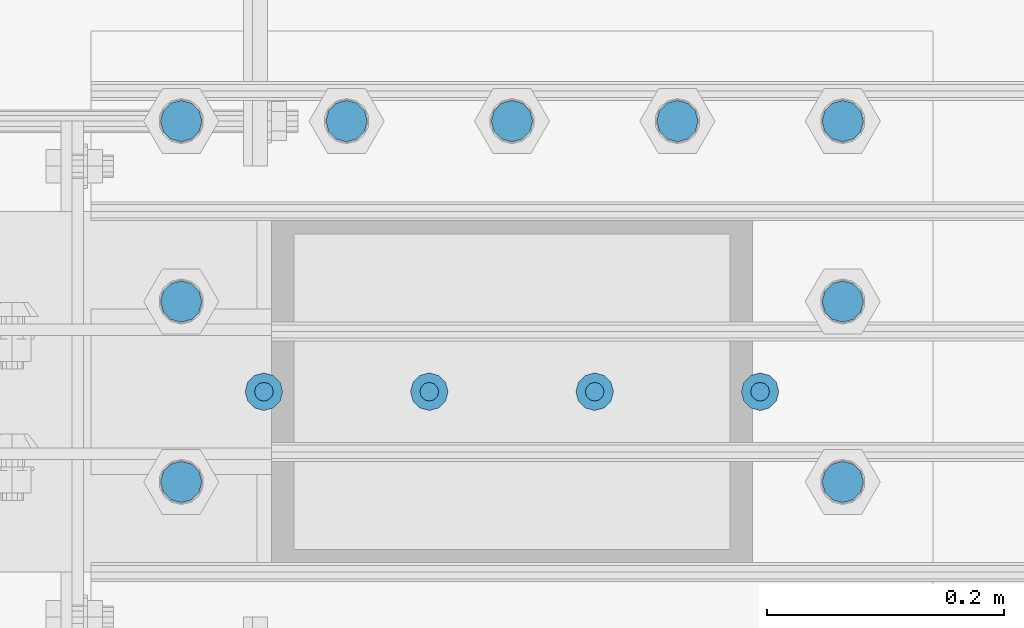
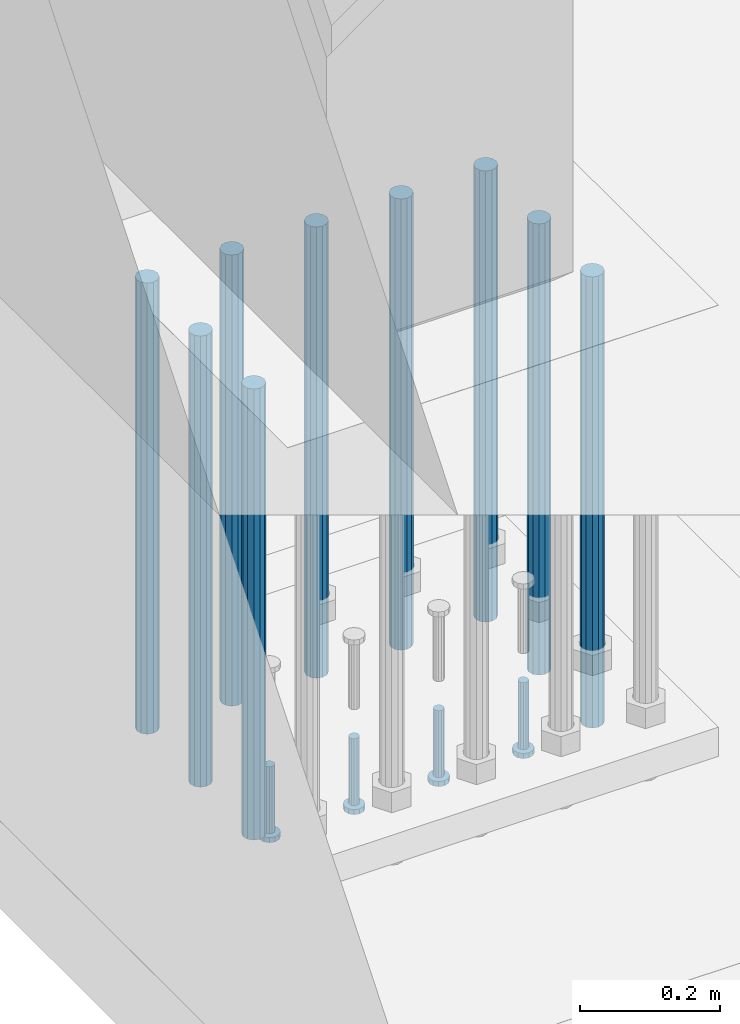
# One storey, part 1090 of 1876: 13 beams, 1 element without a shape of its own.
"""IFC2X3 building model written with IfcOpenShell, lengths in millimetres."""

from ifc_helpers import new_model, si_unit, frame, origin_with_axes, place, context, subcontext, project, spatial, faceted_brep, material, type_object, element, aggregate, save


model = new_model("IFC2X3")

# Units and contexts
model_context = context("Model", 3, precision=1e-05, world=origin_with_axes())
body_context = subcontext(model_context, "Body", "Model", "MODEL_VIEW")
ifc_project = project(units=[si_unit("LENGTHUNIT", "METRE", prefix="MILLI"), si_unit("AREAUNIT", "SQUARE_METRE"), si_unit("VOLUMEUNIT", "CUBIC_METRE"), si_unit("MASSUNIT", "GRAM", prefix="KILO"), si_unit("TIMEUNIT", "SECOND"), si_unit("PLANEANGLEUNIT", "RADIAN"), si_unit("SOLIDANGLEUNIT", "STERADIAN"), si_unit("THERMODYNAMICTEMPERATUREUNIT", "DEGREE_CELSIUS"), si_unit("LUMINOUSINTENSITYUNIT", "LUMEN")], contexts=[model_context])

# Site, building, storey
site_placement = place(None, origin_with_axes())
site = spatial("IfcSite", under=ifc_project, at=site_placement, CompositionType="ELEMENT")
building_placement = place(site_placement, origin_with_axes())
building = spatial("IfcBuilding", under=site, at=building_placement, Name="Undefined", CompositionType="ELEMENT")
storey_placement = place(building_placement, origin_with_axes())
storey = spatial("IfcBuildingStorey", under=building, at=storey_placement, Name="Undefined", CompositionType="ELEMENT", Elevation=0.0)

# Assembly, beams
assembly_placement = place(storey_placement, origin_with_axes())
assembly = element("IfcElementAssembly", 1, at=assembly_placement, inside=storey, Name="PLATE", AssemblyPlace="NOTDEFINED", PredefinedType="RIGID_FRAME")
ifc_material_1 = material(Name="STEEL/A108")
beam_type_1 = type_object("IfcBeamType", Name="5/8-DIA_HEADED ANCHOR STUD", PredefinedType="NOTDEFINED")
beam_1_placement = place(assembly_placement, frame((441.324993896483, -21742.4, -787.400000000001), z_axis=(1.0, 0.0, 0.0), x_axis=(0.0, 0.0, -1.0)))
beam_1 = element("IfcBeam", 2, at=beam_1_placement, type_object=beam_type_1, material=ifc_material_1, Name="HEADED ANCHOR STUD", ObjectType="5/8-DIA_HEADED ANCHOR STUD", context=body_context, shape_type="Brep", body=[
    faceted_brep([(0.0, -7.94000005722046, 0.0), (0.0, -6.86999988555908, -3.97000002861023), (116.84, -6.86999988555908, -3.97000002861023), (116.84, -7.94000005722046, 0.0), (0.0, -3.97000002861023, -6.86999988555908), (116.84, -3.97000002861023, -6.86999988555908), (0.0, 0.0, -7.94000005722046), (116.84, 0.0, -7.94000005722046), (0.0, 3.97000002861023, -6.86999988555908), (116.84, 3.97000002861023, -6.86999988555908), (0.0, 6.86999988555908, -3.97000002861023), (116.84, 6.86999988555908, -3.97000002861023), (0.0, 7.94000005722046, 0.0), (116.84, 7.94000005722046, 0.0), (0.0, 6.86999988555908, 3.97000002861023), (116.84, 6.86999988555908, 3.97000002861023), (0.0, 3.97000002861023, 6.86999988555908), (116.84, 3.97000002861023, 6.86999988555908), (0.0, 0.0, 7.94000005722046), (116.84, 0.0, 7.94000005722046), (0.0, -3.97000002861023, 6.86999988555908), (116.84, -3.97000002861023, 6.86999988555908), (0.0, -6.86999988555908, 3.97000002861023), (116.84, -6.86999988555908, 3.97000002861023), (118.11, -13.75, -7.94000005722046), (118.11, -15.8800001144409, 0.0), (118.11, -7.94000005722046, -13.75), (118.11, 0.0, -15.8800001144409), (118.11, 7.94000005722046, -13.75), (118.11, 13.75, -7.94000005722046), (118.11, 15.8800001144409, 0.0), (118.11, 13.75, 7.94000005722046), (118.11, 7.94000005722046, 13.75), (118.11, 0.0, 15.8800001144409), (118.11, -7.94000005722046, 13.75), (118.11, -13.75, 7.94000005722046), (127.0, -13.75, -7.94000005722046), (127.0, -15.8800001144409, 0.0), (127.0, -7.94000005722046, -13.75), (127.0, 0.0, -15.8800001144409), (127.0, 7.94000005722046, -13.75), (127.0, 13.75, -7.94000005722046), (127.0, 15.8800001144409, 0.0), (127.0, 13.75, 7.94000005722046), (127.0, 7.94000005722046, 13.75), (127.0, 0.0, 15.8800001144409), (127.0, -7.94000005722046, 13.75), (127.0, -13.75, 7.94000005722046)], [[[0, 1, 2, 3]], [[1, 4, 5, 2]], [[4, 6, 7, 5]], [[6, 8, 9, 7]], [[8, 10, 11, 9]], [[10, 12, 13, 11]], [[12, 14, 15, 13]], [[14, 16, 17, 15]], [[16, 18, 19, 17]], [[18, 20, 21, 19]], [[20, 22, 23, 21]], [[22, 0, 3, 23]], [[22, 20, 18, 16, 14, 12, 10, 8, 6, 4, 1, 0]], [[3, 2, 24, 25]], [[2, 5, 26, 24]], [[5, 7, 27, 26]], [[7, 9, 28, 27]], [[9, 11, 29, 28]], [[11, 13, 30, 29]], [[13, 15, 31, 30]], [[15, 17, 32, 31]], [[17, 19, 33, 32]], [[19, 21, 34, 33]], [[21, 23, 35, 34]], [[23, 3, 25, 35]], [[25, 24, 36, 37]], [[24, 26, 38, 36]], [[26, 27, 39, 38]], [[27, 28, 40, 39]], [[28, 29, 41, 40]], [[29, 30, 42, 41]], [[30, 31, 43, 42]], [[31, 32, 44, 43]], [[32, 33, 45, 44]], [[33, 34, 46, 45]], [[34, 35, 47, 46]], [[35, 25, 37, 47]], [[38, 39, 40, 41, 42, 43, 44, 45, 46, 47, 37, 36]]]),
])
beam_2_placement = place(assembly_placement, frame((301.624987792968, -21742.4, -787.400000000001), z_axis=(1.0, 0.0, 0.0), x_axis=(0.0, 0.0, -1.0)))
beam_2 = element("IfcBeam", 3, at=beam_2_placement, type_object=beam_type_1, material=ifc_material_1, Name="HEADED ANCHOR STUD", ObjectType="5/8-DIA_HEADED ANCHOR STUD", context=body_context, shape_type="Brep", body=[
    faceted_brep([(0.0, -7.94000005722046, 0.0), (0.0, -6.86999988555908, -3.97000002861023), (116.84, -6.86999988555908, -3.97000002861023), (116.84, -7.94000005722046, 0.0), (0.0, -3.97000002861023, -6.86999988555908), (116.84, -3.97000002861023, -6.86999988555908), (0.0, 0.0, -7.94000005722046), (116.84, 0.0, -7.94000005722046), (0.0, 3.97000002861023, -6.86999988555908), (116.84, 3.97000002861023, -6.86999988555908), (0.0, 6.86999988555908, -3.97000002861023), (116.84, 6.86999988555908, -3.97000002861023), (0.0, 7.94000005722046, 0.0), (116.84, 7.94000005722046, 0.0), (0.0, 6.86999988555908, 3.97000002861023), (116.84, 6.86999988555908, 3.97000002861023), (0.0, 3.97000002861023, 6.86999988555908), (116.84, 3.97000002861023, 6.86999988555908), (0.0, 0.0, 7.94000005722046), (116.84, 0.0, 7.94000005722046), (0.0, -3.97000002861023, 6.86999988555908), (116.84, -3.97000002861023, 6.86999988555908), (0.0, -6.86999988555908, 3.97000002861023), (116.84, -6.86999988555908, 3.97000002861023), (118.11, -13.75, -7.94000005722046), (118.11, -15.8800001144409, 0.0), (118.11, -7.94000005722046, -13.75), (118.11, 0.0, -15.8800001144409), (118.11, 7.94000005722046, -13.75), (118.11, 13.75, -7.94000005722046), (118.11, 15.8800001144409, 0.0), (118.11, 13.75, 7.94000005722046), (118.11, 7.94000005722046, 13.75), (118.11, 0.0, 15.8800001144409), (118.11, -7.94000005722046, 13.75), (118.11, -13.75, 7.94000005722046), (127.0, -13.75, -7.94000005722046), (127.0, -15.8800001144409, 0.0), (127.0, -7.94000005722046, -13.75), (127.0, 0.0, -15.8800001144409), (127.0, 7.94000005722046, -13.75), (127.0, 13.75, -7.94000005722046), (127.0, 15.8800001144409, 0.0), (127.0, 13.75, 7.94000005722046), (127.0, 7.94000005722046, 13.75), (127.0, 0.0, 15.8800001144409), (127.0, -7.94000005722046, 13.75), (127.0, -13.75, 7.94000005722046)], [[[0, 1, 2, 3]], [[1, 4, 5, 2]], [[4, 6, 7, 5]], [[6, 8, 9, 7]], [[8, 10, 11, 9]], [[10, 12, 13, 11]], [[12, 14, 15, 13]], [[14, 16, 17, 15]], [[16, 18, 19, 17]], [[18, 20, 21, 19]], [[20, 22, 23, 21]], [[22, 0, 3, 23]], [[22, 20, 18, 16, 14, 12, 10, 8, 6, 4, 1, 0]], [[3, 2, 24, 25]], [[2, 5, 26, 24]], [[5, 7, 27, 26]], [[7, 9, 28, 27]], [[9, 11, 29, 28]], [[11, 13, 30, 29]], [[13, 15, 31, 30]], [[15, 17, 32, 31]], [[17, 19, 33, 32]], [[19, 21, 34, 33]], [[21, 23, 35, 34]], [[23, 3, 25, 35]], [[25, 24, 36, 37]], [[24, 26, 38, 36]], [[26, 27, 39, 38]], [[27, 28, 40, 39]], [[28, 29, 41, 40]], [[29, 30, 42, 41]], [[30, 31, 43, 42]], [[31, 32, 44, 43]], [[32, 33, 45, 44]], [[33, 34, 46, 45]], [[34, 35, 47, 46]], [[35, 25, 37, 47]], [[38, 39, 40, 41, 42, 43, 44, 45, 46, 47, 37, 36]]]),
])
beam_3_placement = place(assembly_placement, frame((161.924987792968, -21742.4, -787.400000000001), z_axis=(1.0, 0.0, 0.0), x_axis=(0.0, 0.0, -1.0)))
beam_3 = element("IfcBeam", 4, at=beam_3_placement, type_object=beam_type_1, material=ifc_material_1, Name="HEADED ANCHOR STUD", ObjectType="5/8-DIA_HEADED ANCHOR STUD", context=body_context, shape_type="Brep", body=[
    faceted_brep([(0.0, -7.94000005722046, 0.0), (0.0, -6.86999988555908, -3.97000002861023), (116.84, -6.86999988555908, -3.97000002861023), (116.84, -7.94000005722046, 0.0), (0.0, -3.97000002861023, -6.86999988555908), (116.84, -3.97000002861023, -6.86999988555908), (0.0, 0.0, -7.94000005722046), (116.84, 0.0, -7.94000005722046), (0.0, 3.97000002861023, -6.86999988555908), (116.84, 3.97000002861023, -6.86999988555908), (0.0, 6.86999988555908, -3.97000002861023), (116.84, 6.86999988555908, -3.97000002861023), (0.0, 7.94000005722046, 0.0), (116.84, 7.94000005722046, 0.0), (0.0, 6.86999988555908, 3.97000002861023), (116.84, 6.86999988555908, 3.97000002861023), (0.0, 3.97000002861023, 6.86999988555908), (116.84, 3.97000002861023, 6.86999988555908), (0.0, 0.0, 7.94000005722046), (116.84, 0.0, 7.94000005722046), (0.0, -3.97000002861023, 6.86999988555908), (116.84, -3.97000002861023, 6.86999988555908), (0.0, -6.86999988555908, 3.97000002861023), (116.84, -6.86999988555908, 3.97000002861023), (118.11, -13.75, -7.94000005722046), (118.11, -15.8800001144409, 0.0), (118.11, -7.94000005722046, -13.75), (118.11, 0.0, -15.8800001144409), (118.11, 7.94000005722046, -13.75), (118.11, 13.75, -7.94000005722046), (118.11, 15.8800001144409, 0.0), (118.11, 13.75, 7.94000005722046), (118.11, 7.94000005722046, 13.75), (118.11, 0.0, 15.8800001144409), (118.11, -7.94000005722046, 13.75), (118.11, -13.75, 7.94000005722046), (127.0, -13.75, -7.94000005722046), (127.0, -15.8800001144409, 0.0), (127.0, -7.94000005722046, -13.75), (127.0, 0.0, -15.8800001144409), (127.0, 7.94000005722046, -13.75), (127.0, 13.75, -7.94000005722046), (127.0, 15.8800001144409, 0.0), (127.0, 13.75, 7.94000005722046), (127.0, 7.94000005722046, 13.75), (127.0, 0.0, 15.8800001144409), (127.0, -7.94000005722046, 13.75), (127.0, -13.75, 7.94000005722046)], [[[0, 1, 2, 3]], [[1, 4, 5, 2]], [[4, 6, 7, 5]], [[6, 8, 9, 7]], [[8, 10, 11, 9]], [[10, 12, 13, 11]], [[12, 14, 15, 13]], [[14, 16, 17, 15]], [[16, 18, 19, 17]], [[18, 20, 21, 19]], [[20, 22, 23, 21]], [[22, 0, 3, 23]], [[22, 20, 18, 16, 14, 12, 10, 8, 6, 4, 1, 0]], [[3, 2, 24, 25]], [[2, 5, 26, 24]], [[5, 7, 27, 26]], [[7, 9, 28, 27]], [[9, 11, 29, 28]], [[11, 13, 30, 29]], [[13, 15, 31, 30]], [[15, 17, 32, 31]], [[17, 19, 33, 32]], [[19, 21, 34, 33]], [[21, 23, 35, 34]], [[23, 3, 25, 35]], [[25, 24, 36, 37]], [[24, 26, 38, 36]], [[26, 27, 39, 38]], [[27, 28, 40, 39]], [[28, 29, 41, 40]], [[29, 30, 42, 41]], [[30, 31, 43, 42]], [[31, 32, 44, 43]], [[32, 33, 45, 44]], [[33, 34, 46, 45]], [[34, 35, 47, 46]], [[35, 25, 37, 47]], [[38, 39, 40, 41, 42, 43, 44, 45, 46, 47, 37, 36]]]),
])
beam_4_placement = place(assembly_placement, frame((22.2249877929677, -21742.4, -787.400000000001), z_axis=(1.0, 0.0, 0.0), x_axis=(0.0, 0.0, -1.0)))
beam_4 = element("IfcBeam", 5, at=beam_4_placement, type_object=beam_type_1, material=ifc_material_1, Name="HEADED ANCHOR STUD", ObjectType="5/8-DIA_HEADED ANCHOR STUD", context=body_context, shape_type="Brep", body=[
    faceted_brep([(0.0, -7.94000005722046, 0.0), (0.0, -6.86999988555908, -3.97000002861023), (116.84, -6.86999988555908, -3.97000002861023), (116.84, -7.94000005722046, 0.0), (0.0, -3.97000002861023, -6.86999988555908), (116.84, -3.97000002861023, -6.86999988555908), (0.0, 0.0, -7.94000005722046), (116.84, 0.0, -7.94000005722046), (0.0, 3.97000002861023, -6.86999988555908), (116.84, 3.97000002861023, -6.86999988555908), (0.0, 6.86999988555908, -3.97000002861023), (116.84, 6.86999988555908, -3.97000002861023), (0.0, 7.94000005722046, 0.0), (116.84, 7.94000005722046, 0.0), (0.0, 6.86999988555908, 3.97000002861023), (116.84, 6.86999988555908, 3.97000002861023), (0.0, 3.97000002861023, 6.86999988555908), (116.84, 3.97000002861023, 6.86999988555908), (0.0, 0.0, 7.94000005722046), (116.84, 0.0, 7.94000005722046), (0.0, -3.97000002861023, 6.86999988555908), (116.84, -3.97000002861023, 6.86999988555908), (0.0, -6.86999988555908, 3.97000002861023), (116.84, -6.86999988555908, 3.97000002861023), (118.11, -13.75, -7.94000005722046), (118.11, -15.8800001144409, 0.0), (118.11, -7.94000005722046, -13.75), (118.11, 0.0, -15.8800001144409), (118.11, 7.94000005722046, -13.75), (118.11, 13.75, -7.94000005722046), (118.11, 15.8800001144409, 0.0), (118.11, 13.75, 7.94000005722046), (118.11, 7.94000005722046, 13.75), (118.11, 0.0, 15.8800001144409), (118.11, -7.94000005722046, 13.75), (118.11, -13.75, 7.94000005722046), (127.0, -13.75, -7.94000005722046), (127.0, -15.8800001144409, 0.0), (127.0, -7.94000005722046, -13.75), (127.0, 0.0, -15.8800001144409), (127.0, 7.94000005722046, -13.75), (127.0, 13.75, -7.94000005722046), (127.0, 15.8800001144409, 0.0), (127.0, 13.75, 7.94000005722046), (127.0, 7.94000005722046, 13.75), (127.0, 0.0, 15.8800001144409), (127.0, -7.94000005722046, 13.75), (127.0, -13.75, 7.94000005722046)], [[[0, 1, 2, 3]], [[1, 4, 5, 2]], [[4, 6, 7, 5]], [[6, 8, 9, 7]], [[8, 10, 11, 9]], [[10, 12, 13, 11]], [[12, 14, 15, 13]], [[14, 16, 17, 15]], [[16, 18, 19, 17]], [[18, 20, 21, 19]], [[20, 22, 23, 21]], [[22, 0, 3, 23]], [[22, 20, 18, 16, 14, 12, 10, 8, 6, 4, 1, 0]], [[3, 2, 24, 25]], [[2, 5, 26, 24]], [[5, 7, 27, 26]], [[7, 9, 28, 27]], [[9, 11, 29, 28]], [[11, 13, 30, 29]], [[13, 15, 31, 30]], [[15, 17, 32, 31]], [[17, 19, 33, 32]], [[19, 21, 34, 33]], [[21, 23, 35, 34]], [[23, 3, 25, 35]], [[25, 24, 36, 37]], [[24, 26, 38, 36]], [[26, 27, 39, 38]], [[27, 28, 40, 39]], [[28, 29, 41, 40]], [[29, 30, 42, 41]], [[30, 31, 43, 42]], [[31, 32, 44, 43]], [[32, 33, 45, 44]], [[33, 34, 46, 45]], [[34, 35, 47, 46]], [[35, 25, 37, 47]], [[38, 39, 40, 41, 42, 43, 44, 45, 46, 47, 37, 36]]]),
])
ifc_material_2 = material(Name="STEEL/F1554-55, S1")
beam_type_2 = type_object("IfcBeamType", PredefinedType="NOTDEFINED")
beam_5_placement = place(assembly_placement, frame((371.474987792968, -21513.8, -50.7999999999993), z_axis=(0.0, -1.0, 0.0), x_axis=(0.0, 0.0, -1.0)))
beam_5 = element("IfcBeam", 6, at=beam_5_placement, type_object=beam_type_2, material=ifc_material_2, Name="WELDED HEADED STUD", context=body_context, shape_type="Brep", body=[
    faceted_brep([(0.0, -17.4625, 0.0), (0.0, -15.1229686135857, -8.73125000000073), (787.399999999999, -15.1229686135857, -8.73125000000073), (787.399999999999, -17.4625, 0.0), (0.0, -8.73124999999999, -15.1229686135848), (787.399999999999, -8.73124999999999, -15.1229686135848), (0.0, 0.0, -17.4625000000015), (787.399999999999, 0.0, -17.4625000000015), (0.0, 8.73124999999999, -15.1229686135848), (787.399999999999, 8.73124999999999, -15.1229686135848), (0.0, 15.1229686135858, -8.73125000000073), (787.399999999999, 15.1229686135858, -8.73125000000073), (0.0, 17.4625, 0.0), (787.399999999999, 17.4625, 0.0), (0.0, 15.1229686135858, 8.73125000000073), (787.399999999999, 15.1229686135858, 8.73125000000073), (0.0, 8.73124999999999, 15.1229686135848), (787.399999999999, 8.73124999999999, 15.1229686135848), (0.0, 0.0, 17.4625000000015), (787.399999999999, 0.0, 17.4625000000015), (0.0, -8.73124999999999, 15.1229686135848), (787.399999999999, -8.73124999999999, 15.1229686135848), (0.0, -15.1229686135858, 8.73125000000073), (787.399999999999, -15.1229686135858, 8.73125000000073)], [[[0, 1, 2, 3]], [[1, 4, 5, 2]], [[4, 6, 7, 5]], [[6, 8, 9, 7]], [[8, 10, 11, 9]], [[10, 12, 13, 11]], [[12, 14, 15, 13]], [[14, 16, 17, 15]], [[16, 18, 19, 17]], [[18, 20, 21, 19]], [[20, 22, 23, 21]], [[22, 0, 3, 23]], [[5, 7, 9, 11, 13, 15, 17, 19, 21, 23, 3, 2]], [[22, 20, 18, 16, 14, 12, 10, 8, 6, 4, 1, 0]]]),
])
beam_6_placement = place(assembly_placement, frame((231.774987792968, -21513.8, -50.7999999999993), z_axis=(0.0, -1.0, 0.0), x_axis=(0.0, 0.0, -1.0)))
beam_6 = element("IfcBeam", 7, at=beam_6_placement, type_object=beam_type_2, material=ifc_material_2, Name="WELDED HEADED STUD", context=body_context, shape_type="Brep", body=[
    faceted_brep([(0.0, -17.4625, 0.0), (0.0, -15.1229686135857, -8.73125000000073), (787.399999999999, -15.1229686135857, -8.73125000000073), (787.399999999999, -17.4625, 0.0), (0.0, -8.73124999999999, -15.1229686135848), (787.399999999999, -8.73124999999999, -15.1229686135848), (0.0, 0.0, -17.4625000000015), (787.399999999999, 0.0, -17.4625000000015), (0.0, 8.73124999999999, -15.1229686135848), (787.399999999999, 8.73124999999999, -15.1229686135848), (0.0, 15.1229686135858, -8.73125000000073), (787.399999999999, 15.1229686135858, -8.73125000000073), (0.0, 17.4625, 0.0), (787.399999999999, 17.4625, 0.0), (0.0, 15.1229686135858, 8.73125000000073), (787.399999999999, 15.1229686135858, 8.73125000000073), (0.0, 8.73124999999999, 15.1229686135848), (787.399999999999, 8.73124999999999, 15.1229686135848), (0.0, 0.0, 17.4625000000015), (787.399999999999, 0.0, 17.4625000000015), (0.0, -8.73124999999999, 15.1229686135848), (787.399999999999, -8.73124999999999, 15.1229686135848), (0.0, -15.1229686135858, 8.73125000000073), (787.399999999999, -15.1229686135858, 8.73125000000073)], [[[0, 1, 2, 3]], [[1, 4, 5, 2]], [[4, 6, 7, 5]], [[6, 8, 9, 7]], [[8, 10, 11, 9]], [[10, 12, 13, 11]], [[12, 14, 15, 13]], [[14, 16, 17, 15]], [[16, 18, 19, 17]], [[18, 20, 21, 19]], [[20, 22, 23, 21]], [[22, 0, 3, 23]], [[5, 7, 9, 11, 13, 15, 17, 19, 21, 23, 3, 2]], [[22, 20, 18, 16, 14, 12, 10, 8, 6, 4, 1, 0]]]),
])
beam_7_placement = place(assembly_placement, frame((92.0749877929677, -21513.8, -50.7999999999993), z_axis=(0.0, -1.0, 0.0), x_axis=(0.0, 0.0, -1.0)))
beam_7 = element("IfcBeam", 8, at=beam_7_placement, type_object=beam_type_2, material=ifc_material_2, Name="WELDED HEADED STUD", context=body_context, shape_type="Brep", body=[
    faceted_brep([(0.0, -17.4625, 0.0), (0.0, -15.1229686135857, -8.73125000000073), (787.399999999999, -15.1229686135857, -8.73125000000073), (787.399999999999, -17.4625, 0.0), (0.0, -8.73124999999999, -15.1229686135848), (787.399999999999, -8.73124999999999, -15.1229686135848), (0.0, 0.0, -17.4625000000015), (787.399999999999, 0.0, -17.4625000000015), (0.0, 8.73124999999999, -15.1229686135848), (787.399999999999, 8.73124999999999, -15.1229686135848), (0.0, 15.1229686135858, -8.73125000000073), (787.399999999999, 15.1229686135858, -8.73125000000073), (0.0, 17.4625, 0.0), (787.399999999999, 17.4625, 0.0), (0.0, 15.1229686135858, 8.73125000000073), (787.399999999999, 15.1229686135858, 8.73125000000073), (0.0, 8.73124999999999, 15.1229686135848), (787.399999999999, 8.73124999999999, 15.1229686135848), (0.0, 0.0, 17.4625000000015), (787.399999999999, 0.0, 17.4625000000015), (0.0, -8.73124999999999, 15.1229686135848), (787.399999999999, -8.73124999999999, 15.1229686135848), (0.0, -15.1229686135858, 8.73125000000073), (787.399999999999, -15.1229686135858, 8.73125000000073)], [[[0, 1, 2, 3]], [[1, 4, 5, 2]], [[4, 6, 7, 5]], [[6, 8, 9, 7]], [[8, 10, 11, 9]], [[10, 12, 13, 11]], [[12, 14, 15, 13]], [[14, 16, 17, 15]], [[16, 18, 19, 17]], [[18, 20, 21, 19]], [[20, 22, 23, 21]], [[22, 0, 3, 23]], [[5, 7, 9, 11, 13, 15, 17, 19, 21, 23, 3, 2]], [[22, 20, 18, 16, 14, 12, 10, 8, 6, 4, 1, 0]]]),
])
beam_8_placement = place(assembly_placement, frame((-47.6250122070323, -21666.199991862, -50.7999999999993), z_axis=(0.0, -1.0, 0.0), x_axis=(0.0, 0.0, -1.0)))
beam_8 = element("IfcBeam", 9, at=beam_8_placement, type_object=beam_type_2, material=ifc_material_2, Name="WELDED HEADED STUD", context=body_context, shape_type="Brep", body=[
    faceted_brep([(0.0, -17.4625, 0.0), (0.0, -15.1229686135857, -8.73125000000073), (787.399999999999, -15.1229686135857, -8.73125000000073), (787.399999999999, -17.4625, 0.0), (0.0, -8.73124999999999, -15.1229686135848), (787.399999999999, -8.73124999999999, -15.1229686135848), (0.0, 0.0, -17.4625000000015), (787.399999999999, 0.0, -17.4625000000015), (0.0, 8.73124999999999, -15.1229686135848), (787.399999999999, 8.73124999999999, -15.1229686135848), (0.0, 15.1229686135858, -8.73125000000073), (787.399999999999, 15.1229686135858, -8.73125000000073), (0.0, 17.4625, 0.0), (787.399999999999, 17.4625, 0.0), (0.0, 15.1229686135858, 8.73125000000073), (787.399999999999, 15.1229686135858, 8.73125000000073), (0.0, 8.73124999999999, 15.1229686135848), (787.399999999999, 8.73124999999999, 15.1229686135848), (0.0, 0.0, 17.4625000000015), (787.399999999999, 0.0, 17.4625000000015), (0.0, -8.73124999999999, 15.1229686135848), (787.399999999999, -8.73124999999999, 15.1229686135848), (0.0, -15.1229686135858, 8.73125000000073), (787.399999999999, -15.1229686135858, 8.73125000000073)], [[[0, 1, 2, 3]], [[1, 4, 5, 2]], [[4, 6, 7, 5]], [[6, 8, 9, 7]], [[8, 10, 11, 9]], [[10, 12, 13, 11]], [[12, 14, 15, 13]], [[14, 16, 17, 15]], [[16, 18, 19, 17]], [[18, 20, 21, 19]], [[20, 22, 23, 21]], [[22, 0, 3, 23]], [[5, 7, 9, 11, 13, 15, 17, 19, 21, 23, 3, 2]], [[22, 20, 18, 16, 14, 12, 10, 8, 6, 4, 1, 0]]]),
])
beam_9_placement = place(assembly_placement, frame((-47.6250122070322, -21818.599983724, -50.7999999999993), z_axis=(0.0, -1.0, 0.0), x_axis=(0.0, 0.0, -1.0)))
beam_9 = element("IfcBeam", 10, at=beam_9_placement, type_object=beam_type_2, material=ifc_material_2, Name="WELDED HEADED STUD", context=body_context, shape_type="Brep", body=[
    faceted_brep([(0.0, -17.4625, 0.0), (0.0, -15.1229686135857, -8.73125000000073), (787.399999999999, -15.1229686135857, -8.73125000000073), (787.399999999999, -17.4625, 0.0), (0.0, -8.73124999999999, -15.1229686135848), (787.399999999999, -8.73124999999999, -15.1229686135848), (0.0, 0.0, -17.4625000000015), (787.399999999999, 0.0, -17.4625000000015), (0.0, 8.73124999999999, -15.1229686135848), (787.399999999999, 8.73124999999999, -15.1229686135848), (0.0, 15.1229686135858, -8.73125000000073), (787.399999999999, 15.1229686135858, -8.73125000000073), (0.0, 17.4625, 0.0), (787.399999999999, 17.4625, 0.0), (0.0, 15.1229686135858, 8.73125000000073), (787.399999999999, 15.1229686135858, 8.73125000000073), (0.0, 8.73124999999999, 15.1229686135848), (787.399999999999, 8.73124999999999, 15.1229686135848), (0.0, 0.0, 17.4625000000015), (787.399999999999, 0.0, 17.4625000000015), (0.0, -8.73124999999999, 15.1229686135848), (787.399999999999, -8.73124999999999, 15.1229686135848), (0.0, -15.1229686135858, 8.73125000000073), (787.399999999999, -15.1229686135858, 8.73125000000073)], [[[0, 1, 2, 3]], [[1, 4, 5, 2]], [[4, 6, 7, 5]], [[6, 8, 9, 7]], [[8, 10, 11, 9]], [[10, 12, 13, 11]], [[12, 14, 15, 13]], [[14, 16, 17, 15]], [[16, 18, 19, 17]], [[18, 20, 21, 19]], [[20, 22, 23, 21]], [[22, 0, 3, 23]], [[5, 7, 9, 11, 13, 15, 17, 19, 21, 23, 3, 2]], [[22, 20, 18, 16, 14, 12, 10, 8, 6, 4, 1, 0]]]),
])
beam_10_placement = place(assembly_placement, frame((-47.6250122070323, -21513.8, -50.7999999999993), z_axis=(0.0, -1.0, 0.0), x_axis=(0.0, 0.0, -1.0)))
beam_10 = element("IfcBeam", 11, at=beam_10_placement, type_object=beam_type_2, material=ifc_material_2, Name="WELDED HEADED STUD", context=body_context, shape_type="Brep", body=[
    faceted_brep([(0.0, -17.4625, 0.0), (0.0, -15.1229686135857, -8.73125000000073), (787.399999999999, -15.1229686135857, -8.73125000000073), (787.399999999999, -17.4625, 0.0), (0.0, -8.73124999999999, -15.1229686135848), (787.399999999999, -8.73124999999999, -15.1229686135848), (0.0, 0.0, -17.4625000000015), (787.399999999999, 0.0, -17.4625000000015), (0.0, 8.73124999999999, -15.1229686135848), (787.399999999999, 8.73124999999999, -15.1229686135848), (0.0, 15.1229686135858, -8.73125000000073), (787.399999999999, 15.1229686135858, -8.73125000000073), (0.0, 17.4625, 0.0), (787.399999999999, 17.4625, 0.0), (0.0, 15.1229686135858, 8.73125000000073), (787.399999999999, 15.1229686135858, 8.73125000000073), (0.0, 8.73124999999999, 15.1229686135848), (787.399999999999, 8.73124999999999, 15.1229686135848), (0.0, 0.0, 17.4625000000015), (787.399999999999, 0.0, 17.4625000000015), (0.0, -8.73124999999999, 15.1229686135848), (787.399999999999, -8.73124999999999, 15.1229686135848), (0.0, -15.1229686135858, 8.73125000000073), (787.399999999999, -15.1229686135858, 8.73125000000073)], [[[0, 1, 2, 3]], [[1, 4, 5, 2]], [[4, 6, 7, 5]], [[6, 8, 9, 7]], [[8, 10, 11, 9]], [[10, 12, 13, 11]], [[12, 14, 15, 13]], [[14, 16, 17, 15]], [[16, 18, 19, 17]], [[18, 20, 21, 19]], [[20, 22, 23, 21]], [[22, 0, 3, 23]], [[5, 7, 9, 11, 13, 15, 17, 19, 21, 23, 3, 2]], [[22, 20, 18, 16, 14, 12, 10, 8, 6, 4, 1, 0]]]),
])
beam_11_placement = place(assembly_placement, frame((511.174999999999, -21666.199991862, -50.7999999999993), z_axis=(0.0, -1.0, 0.0), x_axis=(0.0, 0.0, -1.0)))
beam_11 = element("IfcBeam", 12, at=beam_11_placement, type_object=beam_type_2, material=ifc_material_2, Name="WELDED HEADED STUD", context=body_context, shape_type="Brep", body=[
    faceted_brep([(0.0, -17.4625, 0.0), (0.0, -15.1229686135857, -8.73125000000073), (787.399999999999, -15.1229686135857, -8.73125000000073), (787.399999999999, -17.4625, 0.0), (0.0, -8.73124999999999, -15.1229686135848), (787.399999999999, -8.73124999999999, -15.1229686135848), (0.0, 0.0, -17.4625000000015), (787.399999999999, 0.0, -17.4625000000015), (0.0, 8.73124999999999, -15.1229686135848), (787.399999999999, 8.73124999999999, -15.1229686135848), (0.0, 15.1229686135858, -8.73125000000073), (787.399999999999, 15.1229686135858, -8.73125000000073), (0.0, 17.4625, 0.0), (787.399999999999, 17.4625, 0.0), (0.0, 15.1229686135858, 8.73125000000073), (787.399999999999, 15.1229686135858, 8.73125000000073), (0.0, 8.73124999999999, 15.1229686135848), (787.399999999999, 8.73124999999999, 15.1229686135848), (0.0, 0.0, 17.4625000000015), (787.399999999999, 0.0, 17.4625000000015), (0.0, -8.73124999999999, 15.1229686135848), (787.399999999999, -8.73124999999999, 15.1229686135848), (0.0, -15.1229686135858, 8.73125000000073), (787.399999999999, -15.1229686135858, 8.73125000000073)], [[[0, 1, 2, 3]], [[1, 4, 5, 2]], [[4, 6, 7, 5]], [[6, 8, 9, 7]], [[8, 10, 11, 9]], [[10, 12, 13, 11]], [[12, 14, 15, 13]], [[14, 16, 17, 15]], [[16, 18, 19, 17]], [[18, 20, 21, 19]], [[20, 22, 23, 21]], [[22, 0, 3, 23]], [[5, 7, 9, 11, 13, 15, 17, 19, 21, 23, 3, 2]], [[22, 20, 18, 16, 14, 12, 10, 8, 6, 4, 1, 0]]]),
])
beam_12_placement = place(assembly_placement, frame((511.174999999999, -21818.599983724, -50.7999999999993), z_axis=(0.0, -1.0, 0.0), x_axis=(0.0, 0.0, -1.0)))
beam_12 = element("IfcBeam", 13, at=beam_12_placement, type_object=beam_type_2, material=ifc_material_2, Name="WELDED HEADED STUD", context=body_context, shape_type="Brep", body=[
    faceted_brep([(0.0, -17.4625, 0.0), (0.0, -15.1229686135857, -8.73125000000073), (787.399999999999, -15.1229686135857, -8.73125000000073), (787.399999999999, -17.4625, 0.0), (0.0, -8.73124999999999, -15.1229686135848), (787.399999999999, -8.73124999999999, -15.1229686135848), (0.0, 0.0, -17.4625000000015), (787.399999999999, 0.0, -17.4625000000015), (0.0, 8.73124999999999, -15.1229686135848), (787.399999999999, 8.73124999999999, -15.1229686135848), (0.0, 15.1229686135858, -8.73125000000073), (787.399999999999, 15.1229686135858, -8.73125000000073), (0.0, 17.4625, 0.0), (787.399999999999, 17.4625, 0.0), (0.0, 15.1229686135858, 8.73125000000073), (787.399999999999, 15.1229686135858, 8.73125000000073), (0.0, 8.73124999999999, 15.1229686135848), (787.399999999999, 8.73124999999999, 15.1229686135848), (0.0, 0.0, 17.4625000000015), (787.399999999999, 0.0, 17.4625000000015), (0.0, -8.73124999999999, 15.1229686135848), (787.399999999999, -8.73124999999999, 15.1229686135848), (0.0, -15.1229686135858, 8.73125000000073), (787.399999999999, -15.1229686135858, 8.73125000000073)], [[[0, 1, 2, 3]], [[1, 4, 5, 2]], [[4, 6, 7, 5]], [[6, 8, 9, 7]], [[8, 10, 11, 9]], [[10, 12, 13, 11]], [[12, 14, 15, 13]], [[14, 16, 17, 15]], [[16, 18, 19, 17]], [[18, 20, 21, 19]], [[20, 22, 23, 21]], [[22, 0, 3, 23]], [[5, 7, 9, 11, 13, 15, 17, 19, 21, 23, 3, 2]], [[22, 20, 18, 16, 14, 12, 10, 8, 6, 4, 1, 0]]]),
])
beam_13_placement = place(assembly_placement, frame((511.174999999999, -21513.8, -50.7999999999993), z_axis=(0.0, -1.0, 0.0), x_axis=(0.0, 0.0, -1.0)))
beam_13 = element("IfcBeam", 14, at=beam_13_placement, type_object=beam_type_2, material=ifc_material_2, Name="WELDED HEADED STUD", context=body_context, shape_type="Brep", body=[
    faceted_brep([(0.0, -17.4625, 0.0), (0.0, -15.1229686135857, -8.73125000000073), (787.399999999999, -15.1229686135857, -8.73125000000073), (787.399999999999, -17.4625, 0.0), (0.0, -8.73124999999999, -15.1229686135848), (787.399999999999, -8.73124999999999, -15.1229686135848), (0.0, 0.0, -17.4625000000015), (787.399999999999, 0.0, -17.4625000000015), (0.0, 8.73124999999999, -15.1229686135848), (787.399999999999, 8.73124999999999, -15.1229686135848), (0.0, 15.1229686135858, -8.73125000000073), (787.399999999999, 15.1229686135858, -8.73125000000073), (0.0, 17.4625, 0.0), (787.399999999999, 17.4625, 0.0), (0.0, 15.1229686135858, 8.73125000000073), (787.399999999999, 15.1229686135858, 8.73125000000073), (0.0, 8.73124999999999, 15.1229686135848), (787.399999999999, 8.73124999999999, 15.1229686135848), (0.0, 0.0, 17.4625000000015), (787.399999999999, 0.0, 17.4625000000015), (0.0, -8.73124999999999, 15.1229686135848), (787.399999999999, -8.73124999999999, 15.1229686135848), (0.0, -15.1229686135858, 8.73125000000073), (787.399999999999, -15.1229686135858, 8.73125000000073)], [[[0, 1, 2, 3]], [[1, 4, 5, 2]], [[4, 6, 7, 5]], [[6, 8, 9, 7]], [[8, 10, 11, 9]], [[10, 12, 13, 11]], [[12, 14, 15, 13]], [[14, 16, 17, 15]], [[16, 18, 19, 17]], [[18, 20, 21, 19]], [[20, 22, 23, 21]], [[22, 0, 3, 23]], [[5, 7, 9, 11, 13, 15, 17, 19, 21, 23, 3, 2]], [[22, 20, 18, 16, 14, 12, 10, 8, 6, 4, 1, 0]]]),
])
aggregate(assembly, [beam_1, beam_2, beam_3, beam_4, beam_5, beam_6, beam_7, beam_8, beam_9, beam_10, beam_11, beam_12, beam_13])

save(model, "model.ifc")
